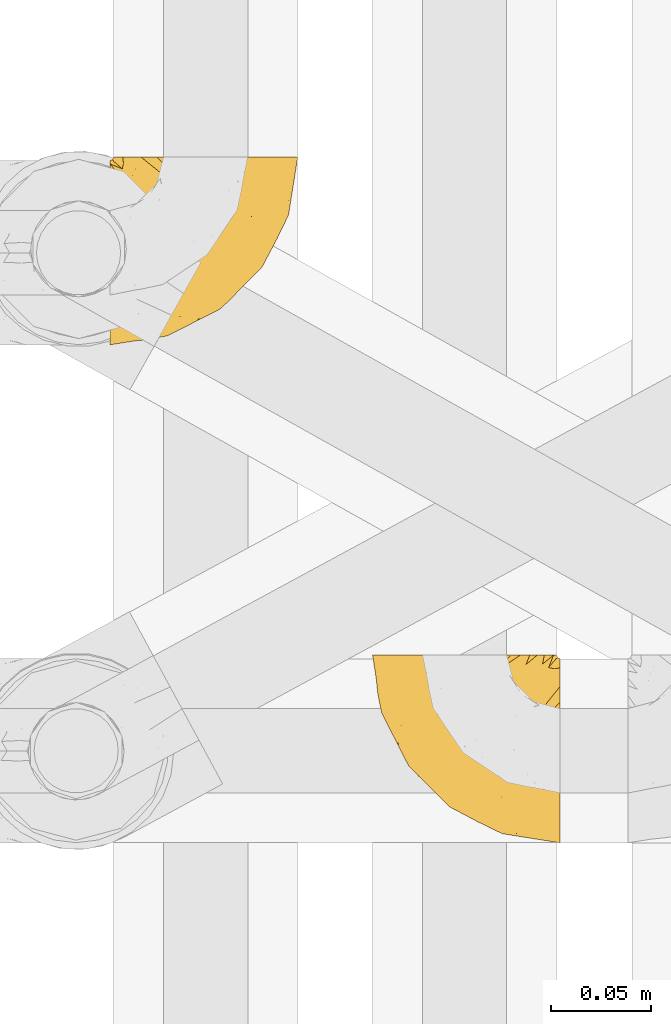
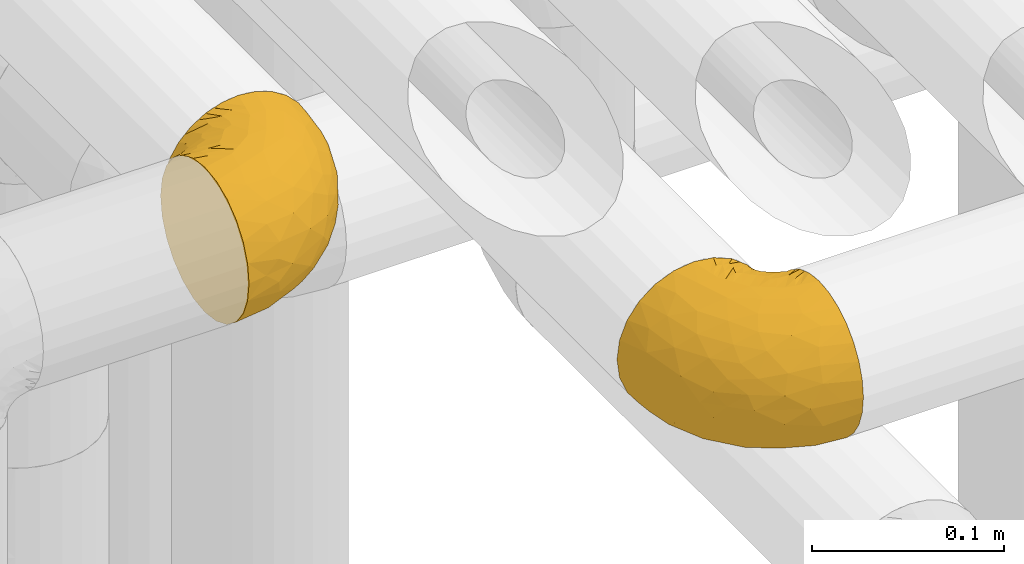
# One storey, part 164 of 827: 2 coverings.
"""IFC2X3 building model written with IfcOpenShell, lengths in millimetres."""

from ifc_helpers import new_model, entity, si_unit, converted_unit, derived_unit, direction, frame, origin, place, context, subcontext, project, spatial, faceted_brep, element, save


model = new_model("IFC2X3")

# Units and contexts
model_context = context("Model", 3, precision=0.01, world=origin(), true_north=direction((6.12303176911189e-17, 1.0)))
body_context = subcontext(model_context, "Body", "Model", "MODEL_VIEW")
ifc_project = project(units=[si_unit("LENGTHUNIT", "METRE", prefix="MILLI"), si_unit("AREAUNIT", "SQUARE_METRE"), si_unit("VOLUMEUNIT", "CUBIC_METRE"), converted_unit("PLANEANGLEUNIT", "DEGREE", entity("IfcRatioMeasure", 0.0174532925199433), si_unit("PLANEANGLEUNIT", "RADIAN"), dimensions=[0, 0, 0, 0, 0, 0, 0]), si_unit("MASSUNIT", "GRAM", prefix="KILO"), derived_unit("MASSDENSITYUNIT", [(si_unit("MASSUNIT", "GRAM", prefix="KILO"), 1), (si_unit("LENGTHUNIT", "METRE"), -3)]), derived_unit("MOMENTOFINERTIAUNIT", [(si_unit("LENGTHUNIT", "METRE"), 4)]), si_unit("TIMEUNIT", "SECOND"), si_unit("FREQUENCYUNIT", "HERTZ"), si_unit("THERMODYNAMICTEMPERATUREUNIT", "DEGREE_CELSIUS"), derived_unit("THERMALTRANSMITTANCEUNIT", [(si_unit("MASSUNIT", "GRAM", prefix="KILO"), 1), (si_unit("THERMODYNAMICTEMPERATUREUNIT", "KELVIN"), -1), (si_unit("TIMEUNIT", "SECOND"), -3)]), derived_unit("VOLUMETRICFLOWRATEUNIT", [(si_unit("LENGTHUNIT", "METRE"), 3), (si_unit("TIMEUNIT", "SECOND"), -1)]), derived_unit("MASSFLOWRATEUNIT", [(si_unit("MASSUNIT", "GRAM", prefix="KILO"), 1), (si_unit("TIMEUNIT", "SECOND"), -1)]), derived_unit("ROTATIONALFREQUENCYUNIT", [(si_unit("TIMEUNIT", "SECOND"), -1)]), si_unit("ELECTRICCURRENTUNIT", "AMPERE"), si_unit("ELECTRICVOLTAGEUNIT", "VOLT"), si_unit("POWERUNIT", "WATT"), si_unit("FORCEUNIT", "NEWTON", prefix="KILO"), si_unit("ILLUMINANCEUNIT", "LUX"), si_unit("LUMINOUSFLUXUNIT", "LUMEN"), si_unit("LUMINOUSINTENSITYUNIT", "CANDELA"), derived_unit("USERDEFINED", [(si_unit("MASSUNIT", "GRAM", prefix="KILO"), -1), (si_unit("LENGTHUNIT", "METRE"), -2), (si_unit("TIMEUNIT", "SECOND"), 3), (si_unit("LUMINOUSFLUXUNIT", "LUMEN"), 1)]), derived_unit("LINEARVELOCITYUNIT", [(si_unit("LENGTHUNIT", "METRE"), 1), (si_unit("TIMEUNIT", "SECOND"), -1)]), si_unit("PRESSUREUNIT", "PASCAL"), derived_unit("USERDEFINED", [(si_unit("LENGTHUNIT", "METRE"), -2), (si_unit("MASSUNIT", "GRAM", prefix="KILO"), 1), (si_unit("TIMEUNIT", "SECOND"), -2)]), derived_unit("LINEARFORCEUNIT", [(si_unit("MASSUNIT", "GRAM", prefix="KILO"), 1), (si_unit("LENGTHUNIT", "METRE"), 1), (si_unit("TIMEUNIT", "SECOND"), -2), (si_unit("LENGTHUNIT", "METRE"), -1)]), derived_unit("PLANARFORCEUNIT", [(si_unit("MASSUNIT", "GRAM", prefix="KILO"), 1), (si_unit("LENGTHUNIT", "METRE"), 1), (si_unit("TIMEUNIT", "SECOND"), -2), (si_unit("LENGTHUNIT", "METRE"), -2)])], contexts=[model_context])

# Site, building, storey
site_placement = place(None, origin())
site = spatial("IfcSite", under=ifc_project, at=site_placement, CompositionType="ELEMENT")
building_placement = place(site_placement, origin())
building = spatial("IfcBuilding", under=site, at=building_placement, CompositionType="ELEMENT")
storey_placement = place(building_placement, frame((0.0, 0.0, 28200.0)))
storey = spatial("IfcBuildingStorey", under=building, at=storey_placement, Name="08", CompositionType="ELEMENT", Elevation=28200.0)

# Coverings
covering_1_placement = place(storey_placement, frame((35290.44, 11758.41, 3152.2)))
element("IfcCovering", 1, at=covering_1_placement, inside=storey, Name=":ADSK_", ObjectType=":ADSK_", PredefinedType="INSULATION", context=body_context, shape_type="Brep", body=[
    faceted_brep([(78.41, 95.8, 83.91), (85.72, 95.8, 76.59), (91.22, 95.8, 67.83), (94.64, 95.8, 58.07), (95.8, 95.8, 47.8), (94.64, 95.8, 37.51), (91.22, 95.8, 27.74), (85.71, 95.8, 18.98), (78.39, 95.8, 11.67), (69.63, 95.8, 6.17), (59.87, 95.8, 2.75), (49.6, 95.8, 1.6), (45.45, 95.8, 2.06), (42.38, 95.8, 2.41), (39.31, 95.8, 2.75), (34.43, 95.8, 4.46), (29.54, 95.8, 6.17), (25.16, 95.8, 8.93), (20.78, 95.8, 11.68), (17.13, 95.8, 15.34), (13.47, 95.8, 19.0), (7.97, 95.8, 27.76), (6.26, 95.8, 32.64), (4.55, 95.8, 37.52), (3.4, 95.8, 47.8), (4.55, 95.8, 58.08), (6.26, 95.8, 62.96), (7.97, 95.8, 67.85), (13.48, 95.8, 76.61), (17.14, 95.8, 80.26), (20.8, 95.8, 83.92), (25.18, 95.8, 86.67), (29.56, 95.8, 89.42), (34.44, 95.8, 91.13), (39.32, 95.8, 92.84), (42.39, 95.8, 93.18), (45.45, 95.8, 93.53), (49.6, 95.8, 94.0), (59.88, 95.8, 92.84), (69.65, 95.8, 89.42), (1.6, 94.0, 47.8), (1.6, 92.42, 35.84), (1.6, 87.81, 24.7), (1.6, 84.13, 19.91), (1.6, 80.46, 15.13), (1.6, 75.68, 11.46), (1.6, 70.9, 7.78), (1.6, 65.32, 5.48), (1.6, 59.75, 3.17), (1.6, 56.14, 2.69), (1.6, 54.06, 2.42), (1.6, 51.97, 2.14), (1.6, 47.8, 1.6), (1.6, 35.84, 3.17), (1.6, 24.7, 7.78), (1.6, 15.13, 15.13), (1.6, 7.78, 24.7), (1.6, 3.17, 35.84), (1.6, 1.6, 47.8), (1.6, 3.17, 59.75), (1.6, 7.78, 70.9), (1.6, 15.13, 80.46), (1.6, 24.7, 87.81), (1.6, 35.84, 92.42), (1.6, 47.8, 94.0), (1.6, 51.97, 93.45), (1.6, 56.14, 92.9), (1.6, 59.75, 92.42), (1.6, 65.32, 90.11), (1.6, 70.9, 87.81), (1.6, 75.68, 84.13), (1.6, 80.46, 80.46), (1.6, 84.13, 75.68), (1.6, 87.81, 70.9), (1.6, 92.42, 59.75), (36.81, 15.84, 71.98), (23.28, 6.99, 63.6), (45.8, 14.39, 59.72), (30.7, 6.21, 47.8), (21.2, 4.26, 55.16), (12.96, 3.39, 47.8), (66.19, 31.2, 63.76), (54.51, 26.47, 72.22), (17.98, 11.44, 74.18), (36.69, 47.66, 92.52), (35.54, 61.85, 94.0), (31.64, 59.25, 94.0), (27.75, 56.65, 94.0), (23.86, 54.05, 94.0), (19.96, 51.45, 94.0), (22.8, 19.8, 82.14), (42.67, 26.22, 80.34), (33.21, 31.58, 87.52), (59.45, 38.36, 79.59), (71.5, 51.54, 78.25), (62.66, 51.6, 85.01), (54.5, 55.97, 90.25), (47.57, 62.88, 93.2), (48.81, 41.35, 87.23), (74.98, 82.24, 85.55), (18.7, 40.88, 93.0), (15.75, 29.0, 89.31), (91.17, 74.06, 61.31), (85.28, 54.53, 56.86), (82.58, 57.98, 68.34), (75.78, 43.81, 65.71), (74.98, 38.22, 56.99), (67.27, 38.33, 72.15), (87.38, 74.76, 70.34), (82.04, 76.85, 78.36), (94.0, 84.43, 47.8), (77.8, 40.43, 47.8), (67.38, 30.01, 47.8), (56.2, 78.67, 93.06), (48.85, 92.06, 94.0), (48.11, 88.32, 94.0), (47.57, 85.6, 94.0), (47.03, 82.88, 94.0), (46.48, 80.15, 94.0), (45.94, 77.43, 94.0), (65.78, 76.36, 89.88), (17.24, 50.91, 94.0), (14.51, 50.37, 94.0), (11.79, 49.82, 94.0), (9.07, 49.28, 94.0), (7.2, 48.91, 94.0), (5.33, 48.54, 94.0), (91.18, 66.69, 47.8), (43.34, 73.53, 94.0), (40.74, 69.64, 94.0), (38.14, 65.75, 94.0), (72.73, 66.13, 83.7), (56.96, 19.59, 47.8), (62.23, 24.64, 55.9), (84.49, 53.56, 47.8), (43.83, 12.9, 47.8), (12.05, 82.81, 81.75), (18.95, 81.22, 86.43), (13.02, 86.57, 79.8), (8.34, 92.75, 69.84), (14.63, 89.68, 79.5), (11.09, 72.26, 88.08), (13.66, 64.73, 91.6), (20.08, 62.45, 92.93), (9.61, 60.63, 92.43), (9.48, 56.91, 93.24), (16.1, 58.14, 93.36), (3.42, 93.7, 57.25), (26.63, 83.4, 89.41), (33.72, 75.54, 92.89), (34.77, 79.46, 92.66), (6.75, 82.28, 79.58), (13.31, 76.25, 86.51), (21.11, 84.69, 86.29), (19.94, 90.18, 83.91), (6.04, 86.94, 73.94), (8.67, 65.12, 90.94), (26.11, 71.71, 91.94), (29.3, 75.21, 91.98), (6.32, 78.6, 82.79), (39.92, 87.27, 93.16), (27.05, 87.92, 88.76), (34.4, 86.1, 91.89), (2.87, 94.52, 47.8), (20.92, 66.23, 92.22), (27.43, 91.08, 88.56), (7.54, 71.77, 87.72), (18.45, 76.21, 88.33), (23.88, 68.59, 92.18), (7.77, 89.94, 71.78), (13.3, 76.25, 9.09), (11.09, 72.26, 7.51), (6.33, 78.6, 12.8), (9.07, 49.28, 1.6), (5.33, 48.54, 1.6), (14.51, 50.37, 1.6), (11.79, 49.82, 1.6), (3.42, 93.7, 38.35), (7.76, 89.95, 23.84), (47.03, 82.88, 1.6), (47.57, 85.6, 1.6), (48.85, 92.06, 1.6), (48.11, 88.32, 1.6), (14.62, 89.68, 16.1), (27.03, 87.92, 6.84), (20.08, 62.45, 2.66), (20.92, 66.24, 3.37), (27.75, 56.65, 1.6), (31.64, 59.25, 1.6), (9.61, 60.63, 3.16), (9.48, 56.91, 2.35), (8.33, 92.76, 25.77), (6.74, 82.28, 16.02), (12.04, 82.81, 13.85), (23.86, 54.05, 1.6), (19.96, 51.45, 1.6), (16.1, 58.14, 2.23), (19.93, 90.18, 11.69), (21.1, 84.7, 9.31), (39.92, 87.25, 2.43), (33.68, 75.58, 2.71), (29.28, 75.2, 3.61), (26.62, 83.39, 6.18), (26.08, 71.7, 3.66), (18.93, 81.22, 9.17), (27.87, 90.73, 6.77), (34.75, 79.47, 2.93), (6.04, 86.94, 21.66), (38.14, 65.75, 1.6), (12.79, 86.75, 16.09), (34.41, 86.08, 3.7), (45.94, 77.43, 1.6), (43.34, 73.53, 1.6), (40.74, 69.64, 1.6), (13.66, 64.73, 3.99), (17.24, 50.91, 1.6), (8.67, 65.12, 4.65), (35.54, 61.85, 1.6), (23.83, 68.62, 3.43), (18.43, 76.22, 7.27), (6.03, 74.03, 9.46), (46.48, 80.15, 1.6), (34.52, 49.81, 2.4), (21.2, 4.26, 40.43), (23.82, 19.95, 13.57), (41.32, 30.61, 11.3), (47.62, 25.71, 18.65), (52.66, 22.43, 27.26), (36.81, 15.85, 23.61), (49.75, 60.69, 3.07), (19.07, 40.49, 2.69), (45.8, 14.39, 35.87), (23.28, 6.99, 31.99), (21.35, 29.56, 6.71), (17.98, 11.45, 21.41), (82.57, 57.98, 27.24), (91.17, 74.06, 34.26), (85.27, 54.52, 38.73), (73.89, 43.47, 26.97), (66.19, 31.2, 31.83), (62.43, 33.27, 23.4), (63.53, 64.26, 6.91), (58.45, 74.29, 3.4), (67.16, 80.41, 5.84), (62.22, 24.64, 39.69), (81.54, 73.62, 17.6), (74.8, 78.98, 10.38), (75.83, 53.69, 20.6), (41.45, 42.86, 5.36), (76.72, 41.67, 35.73), (88.2, 79.66, 24.84), (71.6, 58.41, 13.87), (56.23, 47.11, 9.06), (59.44, 38.37, 15.99)], [[[0, 1, 2, 3, 4, 5, 6, 7, 8, 9, 10, 11, 12, 13, 14, 15, 16, 17, 18, 19, 20, 21, 22, 23, 24, 25, 26, 27, 28, 29, 30, 31, 32, 33, 34, 35, 36, 37, 38, 39]], [[40, 41, 42, 43, 44, 45, 46, 47, 48, 49, 50, 51, 52, 53, 54, 55, 56, 57, 58, 59, 60, 61, 62, 63, 64, 65, 66, 67, 68, 69, 70, 71, 72, 73, 74]], [[75, 76, 77]], [[78, 79, 80]], [[77, 81, 82]], [[76, 75, 83]], [[84, 85, 86, 87, 88, 89]], [[90, 91, 92]], [[76, 60, 59]], [[93, 94, 95]], [[90, 62, 61]], [[83, 61, 60]], [[96, 97, 84]], [[98, 93, 95]], [[0, 39, 99]], [[100, 84, 89]], [[62, 101, 63]], [[2, 102, 3]], [[92, 84, 100]], [[103, 102, 104]], [[103, 105, 106]], [[93, 107, 94]], [[1, 108, 2]], [[92, 101, 90]], [[108, 1, 109]], [[102, 110, 3]], [[93, 82, 107]], [[102, 108, 104]], [[111, 106, 112]], [[109, 0, 99]], [[113, 37, 114, 115, 116, 117, 118, 119]], [[120, 38, 113]], [[100, 89, 121, 122, 123, 124, 125, 126, 64]], [[127, 102, 103]], [[97, 119, 128, 129, 130, 85]], [[99, 120, 131]], [[132, 133, 77]], [[59, 80, 79]], [[1, 0, 109]], [[98, 84, 92]], [[94, 109, 131]], [[120, 39, 38]], [[93, 91, 82]], [[104, 94, 105]], [[97, 113, 119]], [[95, 120, 96]], [[83, 90, 61]], [[91, 93, 98]], [[64, 63, 100]], [[100, 63, 101]], [[77, 76, 79]], [[133, 106, 81]], [[84, 97, 85]], [[113, 96, 120]], [[113, 97, 96]], [[37, 113, 38]], [[110, 102, 127]], [[110, 4, 3]], [[103, 111, 134, 127]], [[90, 75, 91]], [[82, 81, 107]], [[91, 75, 82]], [[77, 82, 75]], [[76, 83, 60]], [[90, 83, 75]], [[105, 107, 81]], [[94, 131, 95]], [[105, 94, 107]], [[109, 94, 104]], [[120, 95, 131]], [[98, 95, 96]], [[84, 98, 96]], [[98, 92, 91]], [[106, 105, 81]], [[103, 104, 105]], [[112, 106, 133]], [[103, 106, 111]], [[112, 133, 132]], [[81, 77, 133]], [[77, 78, 135, 132]], [[120, 99, 39]], [[109, 99, 131]], [[59, 58, 80]], [[59, 79, 76]], [[90, 101, 62]], [[100, 101, 92]], [[2, 108, 102]], [[109, 104, 108]], [[78, 77, 79]], [[136, 137, 138]], [[27, 139, 140]], [[141, 142, 143]], [[144, 145, 121]], [[146, 89, 88]], [[147, 139, 25]], [[148, 149, 150]], [[136, 151, 152]], [[147, 40, 74]], [[24, 147, 25]], [[140, 153, 154]], [[33, 116, 34]], [[73, 151, 155]], [[114, 37, 36, 35, 34, 116, 115]], [[146, 156, 144]], [[157, 85, 130]], [[158, 149, 148]], [[151, 159, 152]], [[117, 33, 160]], [[29, 154, 161]], [[155, 74, 73]], [[162, 128, 119]], [[66, 65, 64, 126, 125, 124, 123, 122, 67]], [[163, 147, 24]], [[27, 140, 28]], [[149, 129, 150]], [[139, 27, 26, 25]], [[68, 144, 69]], [[129, 128, 150]], [[164, 87, 86]], [[130, 129, 149]], [[122, 145, 67]], [[154, 153, 148]], [[162, 119, 160]], [[165, 30, 161]], [[150, 161, 148]], [[128, 162, 150]], [[30, 165, 31]], [[145, 144, 68]], [[89, 146, 144]], [[87, 164, 143]], [[166, 156, 142]], [[88, 87, 143]], [[162, 161, 150]], [[161, 30, 29]], [[154, 29, 28]], [[140, 154, 28]], [[161, 154, 148]], [[140, 137, 153]], [[158, 148, 153]], [[157, 130, 158]], [[153, 137, 158]], [[158, 137, 157]], [[167, 137, 136]], [[168, 85, 157]], [[152, 168, 167]], [[167, 168, 157]], [[164, 152, 141]], [[151, 73, 72]], [[159, 72, 71]], [[88, 142, 146]], [[144, 156, 69]], [[146, 142, 156]], [[70, 166, 71]], [[142, 141, 166]], [[70, 69, 156]], [[141, 159, 71]], [[167, 136, 152]], [[138, 137, 140]], [[155, 136, 169]], [[136, 155, 151]], [[74, 155, 169]], [[152, 159, 141]], [[151, 72, 159]], [[168, 152, 164]], [[137, 167, 157]], [[164, 86, 168]], [[85, 168, 86]], [[116, 33, 117]], [[130, 149, 158]], [[67, 145, 68]], [[121, 89, 144]], [[145, 122, 121]], [[40, 147, 163]], [[169, 147, 74]], [[160, 33, 32]], [[162, 160, 32]], [[160, 119, 118, 117]], [[139, 147, 169]], [[139, 169, 138]], [[162, 32, 31]], [[141, 143, 164]], [[88, 143, 142]], [[71, 166, 141]], [[156, 166, 70]], [[139, 138, 140]], [[169, 136, 138]], [[161, 162, 165]], [[162, 31, 165]], [[170, 171, 172]], [[173, 174, 52, 51, 50, 49, 48, 175, 176]], [[177, 178, 41]], [[179, 15, 180]], [[12, 11, 181, 182, 180, 14, 13]], [[183, 21, 20]], [[19, 18, 184]], [[185, 186, 187]], [[186, 188, 187]], [[43, 172, 44]], [[189, 190, 47]], [[23, 22, 21, 191]], [[170, 192, 193]], [[40, 163, 177]], [[194, 195, 196]], [[24, 23, 177]], [[197, 198, 183]], [[199, 15, 179]], [[178, 177, 191]], [[47, 46, 189]], [[200, 201, 202]], [[201, 203, 204]], [[205, 206, 184]], [[207, 41, 178]], [[16, 15, 199]], [[14, 180, 15]], [[202, 201, 198]], [[208, 201, 200]], [[163, 24, 177]], [[48, 47, 190]], [[196, 195, 189]], [[197, 184, 202]], [[204, 193, 209]], [[210, 211, 212]], [[206, 212, 213]], [[205, 17, 210]], [[184, 206, 202]], [[210, 212, 206]], [[185, 194, 214]], [[189, 215, 190]], [[216, 45, 214]], [[186, 171, 170]], [[189, 216, 196]], [[197, 20, 19]], [[194, 185, 187]], [[197, 183, 20]], [[184, 197, 19]], [[197, 202, 198]], [[206, 200, 202]], [[204, 183, 198]], [[201, 208, 203]], [[203, 208, 217]], [[204, 198, 201]], [[217, 188, 218]], [[193, 219, 170]], [[171, 186, 185]], [[170, 218, 186]], [[170, 219, 218]], [[42, 207, 192]], [[171, 220, 172]], [[216, 189, 46]], [[214, 194, 196]], [[44, 220, 45]], [[214, 196, 216]], [[216, 46, 45]], [[214, 45, 220]], [[192, 43, 42]], [[204, 203, 219]], [[207, 193, 192]], [[209, 193, 178]], [[41, 207, 42]], [[193, 207, 178]], [[43, 192, 172]], [[170, 172, 192]], [[204, 219, 193]], [[219, 203, 218]], [[217, 218, 203]], [[188, 186, 218]], [[206, 213, 200]], [[208, 200, 213]], [[199, 210, 16]], [[215, 189, 195]], [[215, 175, 190]], [[175, 48, 190]], [[199, 179, 221, 211]], [[210, 199, 211]], [[23, 191, 177]], [[40, 177, 41]], [[191, 183, 209]], [[21, 183, 191]], [[205, 18, 17]], [[17, 16, 210]], [[171, 185, 214]], [[172, 220, 44]], [[214, 220, 171]], [[191, 209, 178]], [[204, 209, 183]], [[206, 205, 210]], [[18, 205, 184]], [[222, 195, 194, 187, 188, 217]], [[57, 223, 80]], [[224, 225, 226]], [[226, 227, 228]], [[229, 217, 208, 213, 212, 211]], [[230, 52, 174, 173, 176, 175, 215, 195]], [[231, 232, 228]], [[231, 78, 223]], [[223, 57, 232]], [[224, 233, 225]], [[233, 54, 53]], [[234, 232, 56]], [[56, 55, 234]], [[234, 224, 228]], [[235, 236, 237]], [[224, 55, 54]], [[238, 239, 240]], [[52, 230, 53]], [[241, 242, 243]], [[231, 227, 244]], [[11, 10, 242]], [[236, 6, 5]], [[7, 245, 8]], [[8, 246, 9]], [[238, 247, 235]], [[222, 229, 248]], [[242, 211, 221, 179, 180, 182, 181, 11]], [[233, 53, 230]], [[111, 112, 249]], [[250, 6, 236]], [[246, 251, 241]], [[6, 250, 7]], [[127, 236, 110]], [[248, 229, 252]], [[246, 8, 245]], [[235, 245, 250]], [[236, 5, 110]], [[235, 249, 238]], [[237, 236, 127]], [[243, 9, 246]], [[252, 229, 241]], [[56, 232, 57]], [[222, 230, 195]], [[225, 248, 252]], [[248, 233, 230]], [[54, 233, 224]], [[231, 228, 227]], [[244, 132, 231]], [[248, 225, 233]], [[226, 225, 253]], [[235, 250, 236]], [[245, 7, 250]], [[251, 246, 245]], [[243, 246, 241]], [[247, 245, 235]], [[252, 251, 253]], [[229, 222, 217]], [[230, 222, 248]], [[5, 4, 110]], [[237, 127, 134, 111]], [[238, 249, 239]], [[224, 234, 55]], [[232, 234, 228]], [[242, 241, 229]], [[10, 9, 243]], [[211, 242, 229]], [[10, 243, 242]], [[80, 223, 78]], [[80, 58, 57]], [[231, 223, 232]], [[227, 240, 239]], [[224, 226, 228]], [[240, 226, 253]], [[227, 239, 244]], [[226, 240, 227]], [[251, 247, 253]], [[240, 253, 247]], [[249, 235, 237]], [[237, 111, 249]], [[244, 239, 249]], [[112, 244, 249]], [[135, 78, 231, 132]], [[112, 132, 244]], [[247, 238, 240]], [[245, 247, 251]], [[251, 252, 241]], [[225, 252, 253]]]),
])
covering_2_placement = place(storey_placement, frame((35422.24, 11508.37, 3152.2)))
element("IfcCovering", 2, at=covering_2_placement, inside=storey, Name=":ADSK_", ObjectType=":ADSK_", PredefinedType="INSULATION", context=body_context, shape_type="Brep", body=[
    faceted_brep([(95.8, 18.98, 83.91), (95.8, 11.67, 76.59), (95.8, 6.17, 67.83), (95.8, 2.75, 58.07), (95.8, 1.6, 47.8), (95.8, 2.75, 37.51), (95.8, 6.17, 27.74), (95.8, 11.68, 18.98), (95.8, 19.0, 11.67), (95.8, 27.76, 6.17), (95.8, 37.52, 2.75), (95.8, 47.8, 1.6), (95.8, 51.94, 2.06), (95.8, 55.01, 2.41), (95.8, 58.08, 2.75), (95.8, 62.96, 4.46), (95.8, 67.85, 6.17), (95.8, 72.23, 8.93), (95.8, 76.61, 11.68), (95.8, 80.26, 15.34), (95.8, 83.92, 19.0), (95.8, 89.42, 27.76), (95.8, 91.13, 32.64), (95.8, 92.84, 37.52), (95.8, 94.0, 47.8), (95.8, 92.84, 58.08), (95.8, 91.13, 62.96), (95.8, 89.42, 67.85), (95.8, 83.91, 76.61), (95.8, 80.25, 80.26), (95.8, 76.59, 83.92), (95.8, 72.21, 86.67), (95.8, 67.83, 89.42), (95.8, 62.95, 91.13), (95.8, 58.07, 92.84), (95.8, 55.0, 93.18), (95.8, 51.94, 93.53), (95.8, 47.8, 94.0), (95.8, 37.51, 92.84), (95.8, 27.74, 89.42), (94.0, 95.8, 47.8), (92.42, 95.8, 35.84), (87.81, 95.8, 24.7), (84.13, 95.8, 19.91), (80.46, 95.8, 15.13), (75.68, 95.8, 11.46), (70.9, 95.8, 7.78), (65.32, 95.8, 5.48), (59.75, 95.8, 3.17), (56.14, 95.8, 2.69), (54.06, 95.8, 2.42), (51.97, 95.8, 2.14), (47.8, 95.8, 1.6), (35.84, 95.8, 3.17), (24.7, 95.8, 7.78), (15.13, 95.8, 15.13), (7.78, 95.8, 24.7), (3.17, 95.8, 35.84), (1.6, 95.8, 47.8), (3.17, 95.8, 59.75), (7.78, 95.8, 70.9), (15.13, 95.8, 80.46), (24.7, 95.8, 87.81), (35.84, 95.8, 92.42), (47.8, 95.8, 94.0), (51.97, 95.8, 93.45), (56.14, 95.8, 92.9), (59.75, 95.8, 92.42), (65.32, 95.8, 90.11), (70.9, 95.8, 87.81), (75.68, 95.8, 84.13), (80.46, 95.8, 80.46), (84.13, 95.8, 75.68), (87.81, 95.8, 70.9), (92.42, 95.8, 59.75), (15.84, 60.58, 71.98), (6.99, 74.11, 63.6), (14.39, 51.59, 59.72), (6.21, 66.69, 47.8), (4.26, 76.19, 55.16), (3.39, 84.43, 47.8), (31.2, 31.2, 63.76), (26.47, 42.88, 72.22), (11.44, 79.41, 74.18), (47.66, 60.7, 92.52), (61.85, 61.85, 94.0), (59.25, 65.75, 94.0), (56.65, 69.64, 94.0), (54.05, 73.53, 94.0), (51.45, 77.43, 94.0), (19.8, 74.59, 82.14), (26.22, 54.72, 80.34), (31.58, 64.18, 87.52), (38.36, 37.94, 79.59), (51.54, 25.89, 78.25), (51.6, 34.73, 85.01), (55.97, 42.89, 90.25), (62.88, 49.83, 93.2), (41.35, 48.58, 87.23), (82.24, 22.41, 85.55), (40.88, 78.69, 93.0), (29.0, 81.64, 89.31), (74.06, 6.22, 61.31), (54.53, 12.11, 56.86), (57.98, 14.81, 68.34), (43.81, 21.61, 65.71), (38.22, 22.41, 56.99), (38.33, 30.12, 72.15), (74.76, 10.01, 70.34), (76.85, 15.36, 78.36), (84.43, 3.39, 47.8), (40.43, 19.59, 47.8), (30.01, 30.01, 47.8), (78.67, 41.19, 93.06), (92.06, 48.54, 94.0), (88.32, 49.28, 94.0), (85.6, 49.82, 94.0), (82.88, 50.37, 94.0), (80.15, 50.91, 94.0), (77.43, 51.45, 94.0), (76.36, 31.61, 89.88), (50.91, 80.15, 94.0), (50.37, 82.88, 94.0), (49.82, 85.6, 94.0), (49.28, 88.32, 94.0), (48.91, 90.19, 94.0), (48.54, 92.06, 94.0), (66.69, 6.21, 47.8), (73.53, 54.05, 94.0), (69.64, 56.65, 94.0), (65.75, 59.25, 94.0), (66.13, 24.66, 83.7), (19.59, 40.43, 47.8), (24.64, 35.17, 55.9), (53.56, 12.9, 47.8), (12.9, 53.56, 47.8), (82.81, 85.34, 81.75), (81.22, 78.44, 86.43), (86.57, 84.37, 79.8), (92.75, 89.05, 69.84), (89.68, 82.76, 79.5), (72.26, 86.31, 88.08), (64.73, 83.73, 91.6), (62.45, 77.31, 92.93), (60.63, 87.78, 92.43), (56.91, 87.91, 93.24), (58.14, 81.29, 93.36), (93.7, 93.97, 57.25), (83.4, 70.76, 89.41), (75.54, 63.67, 92.89), (79.46, 62.62, 92.66), (82.28, 90.64, 79.58), (76.25, 84.08, 86.51), (84.69, 76.28, 86.29), (90.18, 77.45, 83.91), (86.94, 91.35, 73.94), (65.12, 88.72, 90.94), (71.71, 71.28, 91.94), (75.21, 68.09, 91.98), (78.6, 91.07, 82.79), (87.27, 57.47, 93.16), (87.92, 70.34, 88.76), (86.1, 62.99, 91.89), (94.52, 94.52, 47.8), (66.23, 76.47, 92.22), (91.08, 69.96, 88.56), (71.77, 89.86, 87.72), (76.21, 78.94, 88.33), (68.59, 73.51, 92.18), (89.94, 89.62, 71.78), (76.22, 78.96, 7.27), (81.22, 78.46, 9.17), (71.7, 71.31, 3.66), (49.28, 88.32, 1.6), (48.54, 92.06, 1.6), (50.37, 82.88, 1.6), (49.82, 85.6, 1.6), (93.7, 93.97, 38.35), (89.95, 89.63, 23.84), (82.88, 50.37, 1.6), (85.6, 49.82, 1.6), (92.06, 48.54, 1.6), (88.32, 49.28, 1.6), (89.68, 82.77, 16.1), (87.92, 70.36, 6.84), (62.45, 77.31, 2.66), (66.24, 76.47, 3.37), (56.65, 69.64, 1.6), (59.25, 65.75, 1.6), (78.6, 91.06, 12.8), (60.63, 87.78, 3.16), (56.91, 87.91, 2.35), (92.76, 89.06, 25.77), (76.25, 84.09, 9.09), (82.28, 90.65, 16.02), (82.81, 85.35, 13.85), (54.05, 73.53, 1.6), (51.45, 77.43, 1.6), (58.14, 81.29, 2.23), (90.18, 77.46, 11.69), (84.7, 76.29, 9.31), (87.25, 57.47, 2.43), (75.58, 63.71, 2.71), (75.2, 68.11, 3.61), (83.39, 70.77, 6.18), (90.73, 69.52, 6.77), (79.47, 62.64, 2.93), (86.94, 91.35, 21.66), (65.75, 59.25, 1.6), (86.75, 84.6, 16.09), (86.08, 62.98, 3.7), (77.43, 51.45, 1.6), (73.53, 54.05, 1.6), (69.64, 56.65, 1.6), (64.73, 83.73, 3.99), (50.91, 80.15, 1.6), (65.12, 88.72, 4.65), (72.26, 86.3, 7.51), (61.85, 61.85, 1.6), (68.62, 73.56, 3.43), (74.03, 91.36, 9.46), (80.15, 50.91, 1.6), (49.81, 62.87, 2.4), (4.26, 76.19, 40.43), (19.95, 73.57, 13.57), (30.61, 56.07, 11.3), (25.71, 49.77, 18.65), (22.43, 44.73, 27.26), (15.85, 60.58, 23.61), (60.69, 47.64, 3.07), (40.49, 78.32, 2.69), (14.39, 51.59, 35.87), (6.99, 74.11, 31.99), (29.56, 76.04, 6.71), (11.45, 79.41, 21.41), (57.98, 14.82, 27.24), (74.06, 6.22, 34.26), (54.52, 12.12, 38.73), (43.47, 23.51, 26.97), (31.2, 31.2, 31.83), (33.27, 34.96, 23.4), (64.26, 33.86, 6.91), (74.29, 38.94, 3.4), (80.41, 30.23, 5.84), (41.67, 20.67, 35.73), (24.64, 35.17, 39.69), (73.62, 15.85, 17.6), (78.98, 22.59, 10.38), (53.69, 21.56, 20.6), (42.86, 55.94, 5.36), (79.66, 9.19, 24.84), (58.41, 25.79, 13.87), (47.11, 41.16, 9.06), (38.37, 37.95, 15.99)], [[[0, 1, 2, 3, 4, 5, 6, 7, 8, 9, 10, 11, 12, 13, 14, 15, 16, 17, 18, 19, 20, 21, 22, 23, 24, 25, 26, 27, 28, 29, 30, 31, 32, 33, 34, 35, 36, 37, 38, 39]], [[40, 41, 42, 43, 44, 45, 46, 47, 48, 49, 50, 51, 52, 53, 54, 55, 56, 57, 58, 59, 60, 61, 62, 63, 64, 65, 66, 67, 68, 69, 70, 71, 72, 73, 74]], [[75, 76, 77]], [[78, 79, 80]], [[77, 81, 82]], [[76, 75, 83]], [[84, 85, 86, 87, 88, 89]], [[90, 91, 92]], [[76, 60, 59]], [[93, 94, 95]], [[90, 62, 61]], [[83, 61, 60]], [[96, 97, 84]], [[98, 93, 95]], [[0, 39, 99]], [[100, 84, 89]], [[62, 101, 63]], [[2, 102, 3]], [[92, 84, 100]], [[103, 102, 104]], [[103, 105, 106]], [[93, 107, 94]], [[1, 108, 2]], [[92, 101, 90]], [[108, 1, 109]], [[102, 110, 3]], [[93, 82, 107]], [[102, 108, 104]], [[111, 106, 112]], [[109, 0, 99]], [[113, 37, 114, 115, 116, 117, 118, 119]], [[120, 38, 113]], [[100, 89, 121, 122, 123, 124, 125, 126, 64]], [[127, 102, 103]], [[97, 119, 128, 129, 130, 85]], [[99, 120, 131]], [[132, 133, 77]], [[59, 80, 79]], [[1, 0, 109]], [[98, 84, 92]], [[94, 109, 131]], [[120, 39, 38]], [[93, 91, 82]], [[104, 94, 105]], [[97, 113, 119]], [[95, 120, 96]], [[83, 90, 61]], [[91, 93, 98]], [[64, 63, 100]], [[100, 63, 101]], [[77, 76, 79]], [[133, 106, 81]], [[84, 97, 85]], [[113, 96, 120]], [[113, 97, 96]], [[37, 113, 38]], [[110, 102, 127]], [[110, 4, 3]], [[103, 111, 134, 127]], [[90, 75, 91]], [[82, 81, 107]], [[91, 75, 82]], [[77, 82, 75]], [[76, 83, 60]], [[90, 83, 75]], [[105, 107, 81]], [[94, 131, 95]], [[105, 94, 107]], [[109, 94, 104]], [[120, 95, 131]], [[98, 95, 96]], [[84, 98, 96]], [[98, 92, 91]], [[106, 105, 81]], [[103, 104, 105]], [[133, 132, 112]], [[103, 106, 111]], [[77, 78, 135, 132]], [[106, 133, 112]], [[77, 133, 81]], [[120, 99, 39]], [[109, 99, 131]], [[59, 58, 80]], [[59, 79, 76]], [[90, 101, 62]], [[100, 101, 92]], [[2, 108, 102]], [[109, 104, 108]], [[78, 77, 79]], [[136, 137, 138]], [[27, 139, 140]], [[141, 142, 143]], [[144, 145, 121]], [[146, 89, 88]], [[147, 139, 25]], [[148, 149, 150]], [[136, 151, 152]], [[147, 40, 74]], [[24, 147, 25]], [[140, 153, 154]], [[33, 116, 34]], [[73, 151, 155]], [[114, 37, 36, 35, 34, 116, 115]], [[146, 156, 144]], [[157, 85, 130]], [[158, 149, 148]], [[151, 159, 152]], [[117, 33, 160]], [[29, 154, 161]], [[155, 74, 73]], [[162, 128, 119]], [[65, 64, 126, 125, 124, 123, 122, 67, 66]], [[163, 147, 24]], [[27, 140, 28]], [[149, 129, 150]], [[139, 27, 26, 25]], [[68, 144, 69]], [[129, 128, 150]], [[164, 87, 86]], [[130, 129, 149]], [[122, 145, 67]], [[154, 153, 148]], [[162, 119, 160]], [[165, 30, 161]], [[150, 161, 148]], [[128, 162, 150]], [[30, 165, 31]], [[145, 144, 68]], [[89, 146, 144]], [[87, 164, 143]], [[166, 156, 142]], [[88, 87, 143]], [[162, 161, 150]], [[161, 30, 29]], [[154, 29, 28]], [[140, 154, 28]], [[161, 154, 148]], [[140, 137, 153]], [[158, 148, 153]], [[157, 130, 158]], [[153, 137, 158]], [[158, 137, 157]], [[167, 137, 136]], [[168, 85, 157]], [[152, 168, 167]], [[167, 168, 157]], [[164, 152, 141]], [[151, 73, 72]], [[159, 72, 71]], [[88, 142, 146]], [[144, 156, 69]], [[146, 142, 156]], [[70, 166, 71]], [[142, 141, 166]], [[70, 69, 156]], [[141, 159, 71]], [[167, 136, 152]], [[138, 137, 140]], [[155, 136, 169]], [[136, 155, 151]], [[74, 155, 169]], [[152, 159, 141]], [[151, 72, 159]], [[168, 152, 164]], [[137, 167, 157]], [[164, 86, 168]], [[85, 168, 86]], [[116, 33, 117]], [[130, 149, 158]], [[67, 145, 68]], [[121, 89, 144]], [[145, 122, 121]], [[40, 147, 163]], [[169, 147, 74]], [[160, 33, 32]], [[162, 160, 32]], [[160, 119, 118, 117]], [[139, 147, 169]], [[139, 169, 138]], [[162, 32, 31]], [[141, 143, 164]], [[88, 143, 142]], [[71, 166, 141]], [[156, 166, 70]], [[139, 138, 140]], [[169, 136, 138]], [[161, 162, 165]], [[162, 31, 165]], [[170, 171, 172]], [[173, 174, 52, 51, 50, 49, 48, 175, 176]], [[177, 178, 41]], [[179, 15, 180]], [[12, 11, 181, 182, 180, 14, 13]], [[183, 21, 20]], [[19, 18, 184]], [[185, 186, 187]], [[186, 188, 187]], [[43, 189, 44]], [[190, 191, 47]], [[23, 22, 21, 192]], [[193, 194, 195]], [[40, 163, 177]], [[196, 197, 198]], [[24, 23, 177]], [[199, 200, 183]], [[201, 15, 179]], [[47, 46, 190]], [[202, 203, 204]], [[203, 172, 171]], [[205, 206, 184]], [[207, 41, 178]], [[16, 15, 201]], [[14, 180, 15]], [[204, 203, 200]], [[208, 203, 202]], [[163, 24, 177]], [[48, 47, 191]], [[198, 197, 190]], [[199, 184, 204]], [[171, 195, 209]], [[210, 211, 212]], [[206, 212, 213]], [[205, 17, 210]], [[184, 206, 204]], [[210, 212, 206]], [[185, 196, 214]], [[190, 215, 191]], [[216, 45, 214]], [[186, 217, 193]], [[190, 216, 198]], [[199, 20, 19]], [[196, 185, 187]], [[199, 183, 20]], [[184, 199, 19]], [[199, 204, 200]], [[206, 202, 204]], [[171, 183, 200]], [[203, 208, 172]], [[172, 208, 218]], [[171, 200, 203]], [[218, 188, 219]], [[195, 170, 193]], [[217, 186, 185]], [[193, 219, 186]], [[193, 170, 219]], [[207, 194, 42]], [[217, 220, 189]], [[216, 190, 46]], [[214, 196, 198]], [[44, 220, 45]], [[214, 198, 216]], [[216, 46, 45]], [[214, 45, 220]], [[42, 194, 43]], [[189, 193, 217]], [[207, 195, 194]], [[209, 195, 178]], [[41, 207, 42]], [[195, 207, 178]], [[43, 194, 189]], [[193, 189, 194]], [[171, 170, 195]], [[170, 172, 219]], [[218, 219, 172]], [[188, 186, 219]], [[206, 213, 202]], [[208, 202, 213]], [[201, 210, 16]], [[215, 190, 197]], [[215, 175, 191]], [[175, 48, 191]], [[201, 179, 221, 211]], [[210, 201, 211]], [[23, 192, 177]], [[40, 177, 41]], [[178, 177, 192]], [[21, 183, 192]], [[209, 192, 183]], [[205, 18, 17]], [[17, 16, 210]], [[217, 185, 214]], [[189, 220, 44]], [[214, 220, 217]], [[192, 209, 178]], [[171, 209, 183]], [[206, 205, 210]], [[18, 205, 184]], [[222, 197, 196, 187, 188, 218]], [[57, 223, 80]], [[224, 225, 226]], [[226, 227, 228]], [[229, 218, 208, 213, 212, 211]], [[230, 52, 174, 173, 176, 175, 215, 197]], [[231, 232, 228]], [[231, 78, 223]], [[223, 57, 232]], [[224, 233, 225]], [[233, 54, 53]], [[234, 232, 56]], [[56, 55, 234]], [[234, 224, 228]], [[235, 236, 237]], [[224, 55, 54]], [[238, 239, 240]], [[52, 230, 53]], [[241, 242, 243]], [[239, 244, 245]], [[11, 10, 242]], [[236, 6, 5]], [[7, 246, 8]], [[8, 247, 9]], [[238, 248, 235]], [[222, 229, 249]], [[242, 211, 221, 179, 180, 182, 181, 11]], [[233, 53, 230]], [[111, 112, 244]], [[250, 6, 236]], [[247, 251, 241]], [[6, 250, 7]], [[127, 236, 110]], [[249, 229, 252]], [[247, 8, 246]], [[235, 246, 250]], [[236, 5, 110]], [[235, 244, 238]], [[237, 236, 127]], [[243, 9, 247]], [[252, 229, 241]], [[56, 232, 57]], [[222, 230, 197]], [[225, 249, 252]], [[249, 233, 230]], [[54, 233, 224]], [[231, 228, 227]], [[245, 132, 231]], [[249, 225, 233]], [[226, 225, 253]], [[235, 250, 236]], [[246, 7, 250]], [[251, 247, 246]], [[243, 247, 241]], [[248, 246, 235]], [[252, 251, 253]], [[229, 222, 218]], [[230, 222, 249]], [[5, 4, 110]], [[237, 127, 134, 111]], [[238, 244, 239]], [[224, 234, 55]], [[232, 234, 228]], [[242, 241, 229]], [[10, 9, 243]], [[211, 242, 229]], [[10, 243, 242]], [[80, 223, 78]], [[80, 58, 57]], [[231, 223, 232]], [[227, 240, 239]], [[224, 226, 228]], [[240, 226, 253]], [[227, 239, 245]], [[226, 240, 227]], [[251, 248, 253]], [[240, 253, 248]], [[244, 235, 237]], [[237, 111, 244]], [[132, 245, 112]], [[112, 245, 244]], [[135, 78, 231, 132]], [[227, 245, 231]], [[248, 238, 240]], [[246, 248, 251]], [[251, 252, 241]], [[225, 252, 253]]]),
])

save(model, "model.ifc")
